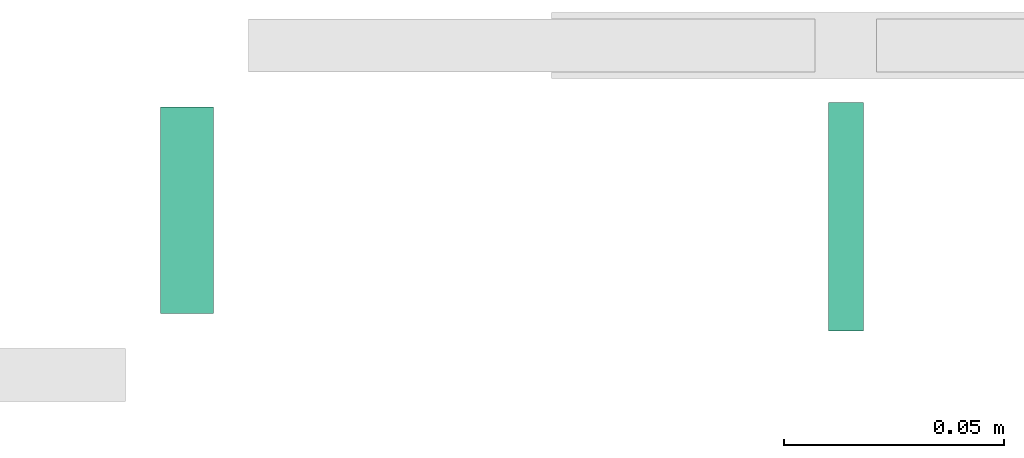
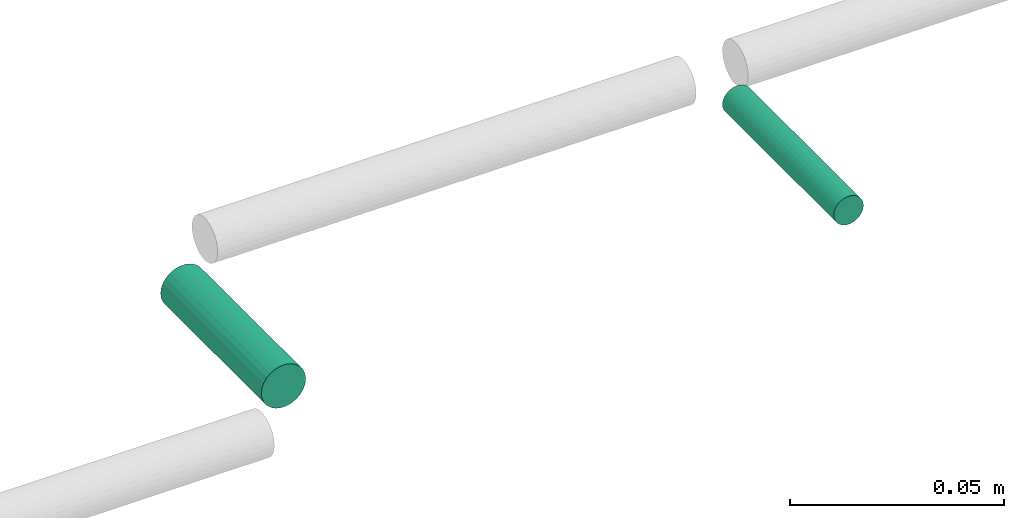
# One storey, part 66 of 89: 2 flow segments.
"""IFC2X3 building model written with IfcOpenShell, lengths in millimetres."""

from ifc_helpers import new_model, entity, si_unit, converted_unit, derived_unit, direction, frame, frame_2d, origin, place, context, subcontext, project, spatial, circle, extrude, type_object, element, save


model = new_model("IFC2X3")

# Units and contexts
model_context = context("Model", 3, precision=0.01, world=origin(), true_north=direction((6.12303176911189e-17, 1.0)))
body_context = subcontext(model_context, "Body", "Model", "MODEL_VIEW")
ifc_project = project(units=[si_unit("LENGTHUNIT", "METRE", prefix="MILLI"), si_unit("AREAUNIT", "SQUARE_METRE"), si_unit("VOLUMEUNIT", "CUBIC_METRE"), converted_unit("PLANEANGLEUNIT", "DEGREE", entity("IfcRatioMeasure", 0.0174532925199433), si_unit("PLANEANGLEUNIT", "RADIAN"), dimensions=[0, 0, 0, 0, 0, 0, 0]), si_unit("MASSUNIT", "GRAM", prefix="KILO"), derived_unit("MASSDENSITYUNIT", [(si_unit("MASSUNIT", "GRAM", prefix="KILO"), 1), (si_unit("LENGTHUNIT", "METRE"), -3)]), derived_unit("MOMENTOFINERTIAUNIT", [(si_unit("LENGTHUNIT", "METRE"), 4)]), si_unit("TIMEUNIT", "SECOND"), si_unit("FREQUENCYUNIT", "HERTZ"), si_unit("THERMODYNAMICTEMPERATUREUNIT", "DEGREE_CELSIUS"), derived_unit("THERMALTRANSMITTANCEUNIT", [(si_unit("MASSUNIT", "GRAM", prefix="KILO"), 1), (si_unit("THERMODYNAMICTEMPERATUREUNIT", "KELVIN"), -1), (si_unit("TIMEUNIT", "SECOND"), -3)]), derived_unit("VOLUMETRICFLOWRATEUNIT", [(si_unit("LENGTHUNIT", "METRE"), 3), (si_unit("TIMEUNIT", "SECOND"), -1)]), derived_unit("MASSFLOWRATEUNIT", [(si_unit("MASSUNIT", "GRAM", prefix="KILO"), 1), (si_unit("TIMEUNIT", "SECOND"), -1)]), derived_unit("ROTATIONALFREQUENCYUNIT", [(si_unit("TIMEUNIT", "SECOND"), -1)]), si_unit("ELECTRICCURRENTUNIT", "AMPERE"), si_unit("ELECTRICVOLTAGEUNIT", "VOLT"), si_unit("POWERUNIT", "WATT"), si_unit("FORCEUNIT", "NEWTON", prefix="KILO"), si_unit("ILLUMINANCEUNIT", "LUX"), si_unit("LUMINOUSFLUXUNIT", "LUMEN"), si_unit("LUMINOUSINTENSITYUNIT", "CANDELA"), derived_unit("USERDEFINED", [(si_unit("MASSUNIT", "GRAM", prefix="KILO"), -1), (si_unit("LENGTHUNIT", "METRE"), -2), (si_unit("TIMEUNIT", "SECOND"), 3), (si_unit("LUMINOUSFLUXUNIT", "LUMEN"), 1)]), derived_unit("LINEARVELOCITYUNIT", [(si_unit("LENGTHUNIT", "METRE"), 1), (si_unit("TIMEUNIT", "SECOND"), -1)]), si_unit("PRESSUREUNIT", "PASCAL"), derived_unit("USERDEFINED", [(si_unit("LENGTHUNIT", "METRE"), -2), (si_unit("MASSUNIT", "GRAM", prefix="KILO"), 1), (si_unit("TIMEUNIT", "SECOND"), -2)]), derived_unit("LINEARFORCEUNIT", [(si_unit("MASSUNIT", "GRAM", prefix="KILO"), 1), (si_unit("LENGTHUNIT", "METRE"), 1), (si_unit("TIMEUNIT", "SECOND"), -2), (si_unit("LENGTHUNIT", "METRE"), -1)]), derived_unit("PLANARFORCEUNIT", [(si_unit("MASSUNIT", "GRAM", prefix="KILO"), 1), (si_unit("LENGTHUNIT", "METRE"), 1), (si_unit("TIMEUNIT", "SECOND"), -2), (si_unit("LENGTHUNIT", "METRE"), -2)])], contexts=[model_context])

# Site, building, storey
site_placement = place(None, frame((0.0, -0.00077364408347762, 0.0)))
site = spatial("IfcSite", under=ifc_project, at=site_placement, CompositionType="ELEMENT")
building_placement = place(site_placement, origin())
building = spatial("IfcBuilding", under=site, at=building_placement, CompositionType="ELEMENT")
storey_placement = place(building_placement, frame((0.0, 0.0, 24000.0)))
storey = spatial("IfcBuildingStorey", under=building, at=storey_placement, CompositionType="ELEMENT", Elevation=24000.0)

# Flow segments
pipe_segment_type = type_object("IfcPipeSegmentType", PredefinedType="NOTDEFINED")
flow_segment_1_placement = place(storey_placement, frame((20765.7336553581, 9210.0, -5480.59527223593)))
element("IfcFlowSegment", 1, at=flow_segment_1_placement, inside=storey, type_object=pipe_segment_type, context=body_context, shape_type="SweptSolid", body=[
    extrude(circle(Radius=4.0, at=frame_2d((-4.33146851719357e-12, 0.0), x_axis=(1.0, 0.0))), frame((5.59527223591499, 0.0, 5.59527223591499), z_axis=(0.0, 1.0, 0.0), x_axis=(-1.0, 0.0, 0.0)), (0.0, 0.0, 1.0), 52.0000000000033),
])
flow_segment_2_placement = place(storey_placement, frame((20613.733655358, 9214.0, -5482.59527223591)))
element("IfcFlowSegment", 2, at=flow_segment_2_placement, inside=storey, type_object=pipe_segment_type, context=body_context, shape_type="SweptSolid", body=[
    extrude(circle(Radius=6.0, at=frame_2d((8.66293703438714e-12, 0.0), x_axis=(1.0, 0.0))), frame((7.5952722359232, 0.0, 7.59527223591454), z_axis=(0.0, 1.0, 0.0), x_axis=(-1.0, 0.0, 0.0)), (0.0, 0.0, 1.0), 46.999999999985),
])

save(model, "model.ifc")
